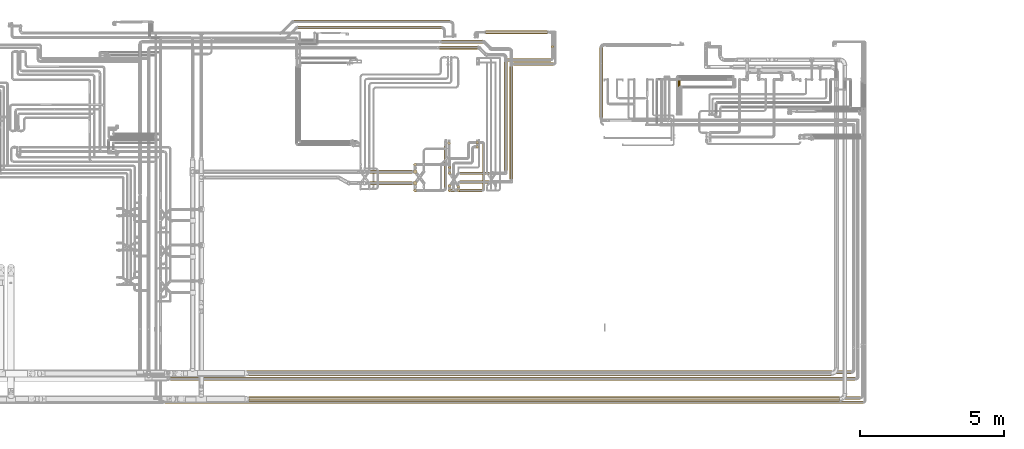
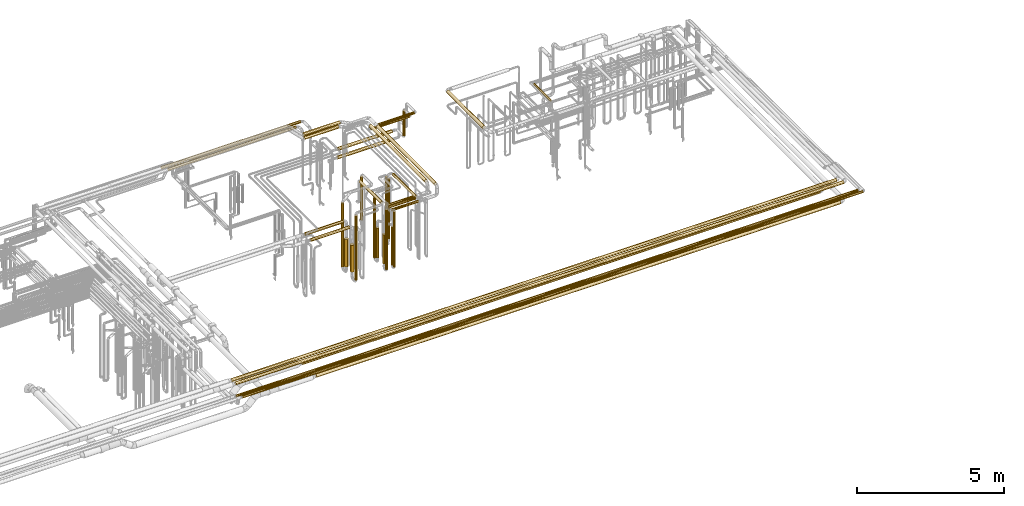
# One storey, part 7 of 827: 39 coverings.
"""IFC2X3 building model written with IfcOpenShell, lengths in millimetres."""

from ifc_helpers import new_model, entity, si_unit, converted_unit, derived_unit, direction, frame, origin, origin_2d_with_axis, place, context, subcontext, project, spatial, circle, extrude, element, save


model = new_model("IFC2X3")

# Units and contexts
model_context = context("Model", 3, precision=0.01, world=origin(), true_north=direction((6.12303176911189e-17, 1.0)))
body_context = subcontext(model_context, "Body", "Model", "MODEL_VIEW")
ifc_project = project(units=[si_unit("LENGTHUNIT", "METRE", prefix="MILLI"), si_unit("AREAUNIT", "SQUARE_METRE"), si_unit("VOLUMEUNIT", "CUBIC_METRE"), converted_unit("PLANEANGLEUNIT", "DEGREE", entity("IfcRatioMeasure", 0.0174532925199433), si_unit("PLANEANGLEUNIT", "RADIAN"), dimensions=[0, 0, 0, 0, 0, 0, 0]), si_unit("MASSUNIT", "GRAM", prefix="KILO"), derived_unit("MASSDENSITYUNIT", [(si_unit("MASSUNIT", "GRAM", prefix="KILO"), 1), (si_unit("LENGTHUNIT", "METRE"), -3)]), derived_unit("MOMENTOFINERTIAUNIT", [(si_unit("LENGTHUNIT", "METRE"), 4)]), si_unit("TIMEUNIT", "SECOND"), si_unit("FREQUENCYUNIT", "HERTZ"), si_unit("THERMODYNAMICTEMPERATUREUNIT", "DEGREE_CELSIUS"), derived_unit("THERMALTRANSMITTANCEUNIT", [(si_unit("MASSUNIT", "GRAM", prefix="KILO"), 1), (si_unit("THERMODYNAMICTEMPERATUREUNIT", "KELVIN"), -1), (si_unit("TIMEUNIT", "SECOND"), -3)]), derived_unit("VOLUMETRICFLOWRATEUNIT", [(si_unit("LENGTHUNIT", "METRE"), 3), (si_unit("TIMEUNIT", "SECOND"), -1)]), derived_unit("MASSFLOWRATEUNIT", [(si_unit("MASSUNIT", "GRAM", prefix="KILO"), 1), (si_unit("TIMEUNIT", "SECOND"), -1)]), derived_unit("ROTATIONALFREQUENCYUNIT", [(si_unit("TIMEUNIT", "SECOND"), -1)]), si_unit("ELECTRICCURRENTUNIT", "AMPERE"), si_unit("ELECTRICVOLTAGEUNIT", "VOLT"), si_unit("POWERUNIT", "WATT"), si_unit("FORCEUNIT", "NEWTON", prefix="KILO"), si_unit("ILLUMINANCEUNIT", "LUX"), si_unit("LUMINOUSFLUXUNIT", "LUMEN"), si_unit("LUMINOUSINTENSITYUNIT", "CANDELA"), derived_unit("USERDEFINED", [(si_unit("MASSUNIT", "GRAM", prefix="KILO"), -1), (si_unit("LENGTHUNIT", "METRE"), -2), (si_unit("TIMEUNIT", "SECOND"), 3), (si_unit("LUMINOUSFLUXUNIT", "LUMEN"), 1)]), derived_unit("LINEARVELOCITYUNIT", [(si_unit("LENGTHUNIT", "METRE"), 1), (si_unit("TIMEUNIT", "SECOND"), -1)]), si_unit("PRESSUREUNIT", "PASCAL"), derived_unit("USERDEFINED", [(si_unit("LENGTHUNIT", "METRE"), -2), (si_unit("MASSUNIT", "GRAM", prefix="KILO"), 1), (si_unit("TIMEUNIT", "SECOND"), -2)]), derived_unit("LINEARFORCEUNIT", [(si_unit("MASSUNIT", "GRAM", prefix="KILO"), 1), (si_unit("LENGTHUNIT", "METRE"), 1), (si_unit("TIMEUNIT", "SECOND"), -2), (si_unit("LENGTHUNIT", "METRE"), -1)]), derived_unit("PLANARFORCEUNIT", [(si_unit("MASSUNIT", "GRAM", prefix="KILO"), 1), (si_unit("LENGTHUNIT", "METRE"), 1), (si_unit("TIMEUNIT", "SECOND"), -2), (si_unit("LENGTHUNIT", "METRE"), -2)])], contexts=[model_context])

# Site, building, storey
site_placement = place(None, origin())
site = spatial("IfcSite", under=ifc_project, at=site_placement, CompositionType="ELEMENT")
building_placement = place(site_placement, origin())
building = spatial("IfcBuilding", under=site, at=building_placement, CompositionType="ELEMENT")
storey_placement = place(building_placement, frame((0.0, 0.0, 28200.0)))
storey = spatial("IfcBuildingStorey", under=building, at=storey_placement, Name="08", CompositionType="ELEMENT", Elevation=28200.0)

# Coverings
covering_1_placement = place(storey_placement, frame((48780.69, 14028.51, 2935.65)))
element("IfcCovering", 1, at=covering_1_placement, inside=storey, Name=":ADSK_", ObjectType=":ADSK_", PredefinedType="INSULATION", context=body_context, shape_type="SweptSolid", body=[
    extrude(circle(Radius=62.75, at=origin_2d_with_axis()), frame((64.35, 0.0, 64.35), z_axis=(0.0, 1.0, 0.0), x_axis=(1.0, 0.0, 0.0)), (0.0, 0.0, 1.0), 3926.02173625165),
])
covering_2_placement = place(storey_placement, frame((46413.17, 18745.48, 2935.65)))
element("IfcCovering", 2, at=covering_2_placement, inside=storey, Name=":ADSK_", ObjectType=":ADSK_", PredefinedType="INSULATION", context=body_context, shape_type="SweptSolid", body=[
    extrude(circle(Radius=62.75, at=origin_2d_with_axis()), frame((0.0, 64.35, 64.35), z_axis=(1.0, 0.0, 0.0), x_axis=(0.0, -1.0, 0.0)), (0.0, 0.0, 1.0), 1431.19890326369),
])
covering_3_placement = place(storey_placement, frame((47057.67, 13882.91, 2546.86)))
element("IfcCovering", 3, at=covering_3_placement, inside=storey, Name=":ADSK_", ObjectType=":ADSK_", PredefinedType="INSULATION", context=body_context, shape_type="SweptSolid", body=[
    extrude(circle(Radius=49.0, at=origin_2d_with_axis()), frame((0.0, 50.6, 50.6), z_axis=(1.0, 0.0, 0.0), x_axis=(0.0, -1.0, 0.0)), (0.0, 0.0, 1.0), 1048.36321743802),
])
covering_4_placement = place(storey_placement, frame((51904.03, 16167.38, 2885.66)))
element("IfcCovering", 4, at=covering_4_placement, inside=storey, Name=":ADSK_", ObjectType=":ADSK_", PredefinedType="INSULATION", context=body_context, shape_type="SweptSolid", body=[
    extrude(circle(Radius=62.75, at=origin_2d_with_axis()), frame((64.34, 0.0, 64.34), z_axis=(0.0, 1.0, 0.0), x_axis=(-0.705020157657856, 0.0, -0.709187265322843)), (0.0, 0.0, 1.0), 2437.8284365613),
])
covering_5_placement = place(storey_placement, frame((36979.83, 7015.65, 3035.65)))
element("IfcCovering", 5, at=covering_5_placement, inside=storey, Name=":ADSK_", ObjectType=":ADSK_", PredefinedType="INSULATION", context=body_context, shape_type="SweptSolid", body=[
    extrude(circle(Radius=62.75, at=origin_2d_with_axis()), frame((0.0, 64.35, 64.35), z_axis=(1.0, 0.0, 0.0), x_axis=(0.0, -1.0, 0.0)), (0.0, 0.0, 1.0), 23828.2704925099),
])
covering_6_placement = place(storey_placement, frame((48580.5, 14330.68, 2935.65)))
element("IfcCovering", 6, at=covering_6_placement, inside=storey, Name=":ADSK_", ObjectType=":ADSK_", PredefinedType="INSULATION", context=body_context, shape_type="SweptSolid", body=[
    extrude(circle(Radius=62.75, at=origin_2d_with_axis()), frame((64.35, 0.0, 64.35), z_axis=(0.0, 1.0, 0.0), x_axis=(1.0, 0.0, 0.0)), (0.0, 0.0, 1.0), 3773.85017283484),
])
covering_7_placement = place(storey_placement, frame((46333.17, 18542.35, 2935.65)))
element("IfcCovering", 7, at=covering_7_placement, inside=storey, Name=":ADSK_", ObjectType=":ADSK_", PredefinedType="INSULATION", context=body_context, shape_type="SweptSolid", body=[
    extrude(circle(Radius=62.75, at=origin_2d_with_axis()), frame((0.0, 64.35, 64.35), z_axis=(1.0, 0.0, 0.0), x_axis=(0.0, -1.0, 0.0)), (0.0, 0.0, 1.0), 1341.29942314912),
])
covering_8_placement = place(storey_placement, frame((47053.03, 14185.08, 2554.4)))
element("IfcCovering", 8, at=covering_8_placement, inside=storey, Name=":ADSK_", ObjectType=":ADSK_", PredefinedType="INSULATION", context=body_context, shape_type="SweptSolid", body=[
    extrude(circle(Radius=49.0, at=origin_2d_with_axis()), frame((0.0, 50.6, 50.6), z_axis=(1.0, 0.0, 0.0), x_axis=(0.0, -1.0, 0.0)), (0.0, 0.0, 1.0), 1022.80865450649),
])
covering_9_placement = place(storey_placement, frame((39691.04, 7183.11, 2816.78)))
element("IfcCovering", 9, at=covering_9_placement, inside=storey, Name=":ADSK_", ObjectType=":ADSK_", PredefinedType="INSULATION", context=body_context, shape_type="SweptSolid", body=[
    extrude(circle(Radius=81.5, at=origin_2d_with_axis()), frame((0.0, 83.1, 83.1), z_axis=(1.0, 0.0, 4.27481930448548e-06), x_axis=(0.0, -1.0, 0.0)), (0.0, 0.0, 1.0), 20277.5004791467),
])
covering_10_placement = place(storey_placement, frame((43864.22, 14225.77, 2439.15)))
element("IfcCovering", 10, at=covering_10_placement, inside=storey, Name=":ADSK_", ObjectType=":ADSK_", PredefinedType="INSULATION", context=body_context, shape_type="SweptSolid", body=[
    extrude(circle(Radius=59.25, at=origin_2d_with_axis()), frame((0.0, 60.85, 60.85), z_axis=(1.0, 0.0, 0.0), x_axis=(0.0, -1.0, 0.0)), (0.0, 0.0, 1.0), 1516.0),
])
covering_11_placement = place(storey_placement, frame((41411.59, 19252.89, 2945.65)))
element("IfcCovering", 11, at=covering_11_placement, inside=storey, Name=":ADSK_", ObjectType=":ADSK_", PredefinedType="INSULATION", context=body_context, shape_type="SweptSolid", body=[
    extrude(circle(Radius=52.75, at=origin_2d_with_axis()), frame((0.0, 54.35, 54.35), z_axis=(1.0, 0.0, 0.0), x_axis=(0.0, 1.0, 0.0)), (0.0, 0.0, 1.0), 5001.22814555646),
])
covering_12_placement = place(storey_placement, frame((36633.72, 6365.97, 3049.4)))
element("IfcCovering", 12, at=covering_12_placement, inside=storey, Name=":ADSK_", ObjectType=":ADSK_", PredefinedType="INSULATION", context=body_context, shape_type="SweptSolid", body=[
    extrude(circle(Radius=49.0, at=origin_2d_with_axis()), frame((0.0, 50.6, 50.6), z_axis=(1.0, 0.0, 0.0), x_axis=(0.0, -1.0, 0.0)), (0.0, 0.0, 1.0), 24361.9213538406),
])
covering_13_placement = place(storey_placement, frame((36794.64, 6215.11, 3049.4)))
element("IfcCovering", 13, at=covering_13_placement, inside=storey, Name=":ADSK_", ObjectType=":ADSK_", PredefinedType="INSULATION", context=body_context, shape_type="SweptSolid", body=[
    extrude(circle(Radius=49.0, at=origin_2d_with_axis()), frame((0.0, 50.6, 50.6), z_axis=(1.0, 0.0, 0.0), x_axis=(0.0, -1.0, 0.0)), (0.0, 0.0, 1.0), 24300.9943574319),
])
covering_14_placement = place(storey_placement, frame((54648.84, 16326.56, 2956.65)))
element("IfcCovering", 14, at=covering_14_placement, inside=storey, Name=":ADSK_", ObjectType=":ADSK_", PredefinedType="INSULATION", context=body_context, shape_type="SweptSolid", body=[
    extrude(circle(Radius=41.75, at=origin_2d_with_axis()), frame((43.35, 0.0, 43.35), z_axis=(0.0, 1.0, 0.0), x_axis=(1.0, 0.0, 0.0)), (0.0, 0.0, 1.0), 1135.43813554226),
])
covering_15_placement = place(storey_placement, frame((46642.19, 14383.93, 457.0)))
element("IfcCovering", 15, at=covering_15_placement, inside=storey, Name=":ADSK_", ObjectType=":ADSK_", PredefinedType="INSULATION", context=body_context, shape_type="SweptSolid", body=[
    extrude(circle(Radius=49.0, at=origin_2d_with_axis()), frame((50.6, 50.6, 0.0)), (0.0, 0.0, 1.0), 2486.00000000001),
])
covering_16_placement = place(storey_placement, frame((47601.15, 15256.43, 1498.5)))
element("IfcCovering", 16, at=covering_16_placement, inside=storey, Name=":ADSK_", ObjectType=":ADSK_", PredefinedType="INSULATION", context=body_context, shape_type="SweptSolid", body=[
    extrude(circle(Radius=49.0, at=origin_2d_with_axis()), frame((50.6, 50.6, 0.0), z_axis=(0.0, 0.0, 1.0), x_axis=(0.0, 1.0, 0.0)), (0.0, 0.0, 1.0), 1444.50064453807),
])
covering_17_placement = place(storey_placement, frame((46636.19, 14182.93, 586.0)))
element("IfcCovering", 17, at=covering_17_placement, inside=storey, Name=":ADSK_", ObjectType=":ADSK_", PredefinedType="INSULATION", context=body_context, shape_type="SweptSolid", body=[
    extrude(circle(Radius=55.0, at=origin_2d_with_axis()), frame((56.6, 56.6, 0.0), z_axis=(0.0, 0.0, 1.0), x_axis=(0.0, -1.0, 0.0)), (0.0, 0.0, 1.0), 1235.49999999998),
])
covering_18_placement = place(storey_placement, frame((47833.42, 13693.84, 2949.4)))
element("IfcCovering", 18, at=covering_18_placement, inside=storey, Name=":ADSK_", ObjectType=":ADSK_", PredefinedType="INSULATION", context=body_context, shape_type="SweptSolid", body=[
    extrude(circle(Radius=49.0, at=origin_2d_with_axis()), frame((50.6, 0.0, 50.6), z_axis=(0.0, 1.0, 0.0), x_axis=(-1.0, 0.0, 0.0)), (0.0, 0.0, 1.0), 1556.18693752511),
])
covering_19_placement = place(storey_placement, frame((46642.19, 13586.24, 457.0)))
element("IfcCovering", 19, at=covering_19_placement, inside=storey, Name=":ADSK_", ObjectType=":ADSK_", PredefinedType="INSULATION", context=body_context, shape_type="SweptSolid", body=[
    extrude(circle(Radius=49.0, at=origin_2d_with_axis()), frame((50.6, 50.6, 0.0), z_axis=(0.0, 0.0, 1.0), x_axis=(0.0, 1.0, 0.0)), (0.0, 0.0, 1.0), 2486.00000000002),
])
covering_20_placement = place(storey_placement, frame((46749.79, 13586.24, 2949.4)))
element("IfcCovering", 20, at=covering_20_placement, inside=storey, Name=":ADSK_", ObjectType=":ADSK_", PredefinedType="INSULATION", context=body_context, shape_type="SweptSolid", body=[
    extrude(circle(Radius=49.0, at=origin_2d_with_axis()), frame((0.0, 50.6, 50.6), z_axis=(1.0, 0.0, 0.0), x_axis=(0.0, -1.0, 0.0)), (0.0, 0.0, 1.0), 1077.22604286538),
])
covering_21_placement = place(storey_placement, frame((46636.19, 13731.91, 617.02)))
element("IfcCovering", 21, at=covering_21_placement, inside=storey, Name=":ADSK_", ObjectType=":ADSK_", PredefinedType="INSULATION", context=body_context, shape_type="SweptSolid", body=[
    extrude(circle(Radius=55.0, at=origin_2d_with_axis()), frame((56.6, 56.6, 0.0), z_axis=(0.0, 0.0, 1.0), x_axis=(0.0, -1.0, 0.0)), (0.0, 0.0, 1.0), 1204.4784639113),
])
covering_22_placement = place(storey_placement, frame((46947.93, 13586.25, 456.98)))
element("IfcCovering", 22, at=covering_22_placement, inside=storey, Name=":ADSK_", ObjectType=":ADSK_", PredefinedType="INSULATION", context=body_context, shape_type="SweptSolid", body=[
    extrude(circle(Radius=49.0, at=origin_2d_with_axis()), frame((50.6, 50.97, 0.01), z_axis=(-2.64985640330363e-08, -0.000162783161270818, 0.999999986750821), x_axis=(1.0, -7.51245479154553e-08, 2.64863353725597e-08)), (0.0, 0.0, 1.0), 2295.79650227157),
])
covering_23_placement = place(storey_placement, frame((47601.15, 15100.64, 477.25)))
element("IfcCovering", 23, at=covering_23_placement, inside=storey, Name=":ADSK_", ObjectType=":ADSK_", PredefinedType="INSULATION", context=body_context, shape_type="SweptSolid", body=[
    extrude(circle(Radius=49.0, at=origin_2d_with_axis()), frame((50.6, 50.6, 0.0), z_axis=(0.0, 0.0, 1.0), x_axis=(-1.0, 0.0, 0.0)), (0.0, 0.0, 1.0), 2465.75),
])
covering_24_placement = place(storey_placement, frame((46948.0, 13713.24, 457.0)))
element("IfcCovering", 24, at=covering_24_placement, inside=storey, Name=":ADSK_", ObjectType=":ADSK_", PredefinedType="INSULATION", context=body_context, shape_type="SweptSolid", body=[
    extrude(circle(Radius=49.0, at=origin_2d_with_axis()), frame((50.53, 50.53, 0.0), z_axis=(0.0, 0.0, 1.0), x_axis=(0.839206573460922, 0.543812768386306, 0.0)), (0.0, 0.0, 1.0), 1586.11232988612),
])
covering_25_placement = place(storey_placement, frame((48701.84, 18129.93, 2749.4)))
element("IfcCovering", 25, at=covering_25_placement, inside=storey, Name=":ADSK_", ObjectType=":ADSK_", PredefinedType="INSULATION", context=body_context, shape_type="SweptSolid", body=[
    extrude(circle(Radius=49.0, at=origin_2d_with_axis()), frame((0.0, 50.6, 50.6), z_axis=(1.0, 0.0, 0.0), x_axis=(0.0, 1.0, 0.0)), (0.0, 0.0, 1.0), 1513.19134551545),
])
covering_26_placement = place(storey_placement, frame((50221.44, 18589.93, 1707.0)))
element("IfcCovering", 26, at=covering_26_placement, inside=storey, Name=":ADSK_", ObjectType=":ADSK_", PredefinedType="INSULATION", context=body_context, shape_type="SweptSolid", body=[
    extrude(circle(Radius=49.0, at=origin_2d_with_axis()), frame((50.6, 50.6, 0.0), z_axis=(0.0, 0.0, 1.0), x_axis=(-1.0, 0.0, 0.0)), (0.0, 0.0, 1.0), 1036.00000000006),
])
covering_27_placement = place(storey_placement, frame((47963.3, 19076.88, 1585.65)))
element("IfcCovering", 27, at=covering_27_placement, inside=storey, Name=":ADSK_", ObjectType=":ADSK_", PredefinedType="INSULATION", context=body_context, shape_type="SweptSolid", body=[
    extrude(circle(Radius=62.75, at=origin_2d_with_axis()), frame((0.0, 64.35, 64.35), z_axis=(1.0, 0.0, 0.0), x_axis=(0.0, 1.0, 0.0)), (0.0, 0.0, 1.0), 2120.0),
])
covering_28_placement = place(storey_placement, frame((48912.03, 17979.93, 2949.4)))
element("IfcCovering", 28, at=covering_28_placement, inside=storey, Name=":ADSK_", ObjectType=":ADSK_", PredefinedType="INSULATION", context=body_context, shape_type="SweptSolid", body=[
    extrude(circle(Radius=49.0, at=origin_2d_with_axis()), frame((0.0, 50.6, 50.6), z_axis=(1.0, 0.0, 0.0), x_axis=(0.0, 1.0, 0.0)), (0.0, 0.0, 1.0), 1403.0),
])
covering_29_placement = place(storey_placement, frame((47950.3, 19076.88, 1235.65)))
element("IfcCovering", 29, at=covering_29_placement, inside=storey, Name=":ADSK_", ObjectType=":ADSK_", PredefinedType="INSULATION", context=body_context, shape_type="SweptSolid", body=[
    extrude(circle(Radius=62.75, at=origin_2d_with_axis()), frame((0.0, 64.35, 64.35), z_axis=(1.0, 0.0, 0.0), x_axis=(0.0, -1.0, 0.0)), (0.0, 0.0, 1.0), 2145.73797712595),
])
covering_30_placement = place(storey_placement, frame((45439.88, 14483.73, 445.0)))
element("IfcCovering", 30, at=covering_30_placement, inside=storey, Name=":ADSK_", ObjectType=":ADSK_", PredefinedType="INSULATION", context=body_context, shape_type="SweptSolid", body=[
    extrude(circle(Radius=52.75, at=origin_2d_with_axis()), frame((54.35, 54.35, 0.0), z_axis=(0.0, 0.0, 1.0), x_axis=(-1.0, 0.0, 0.0)), (0.0, 0.0, 1.0), 2637.31109246141),
])
covering_31_placement = place(storey_placement, frame((46616.22, 15223.73, 1518.25)))
element("IfcCovering", 31, at=covering_31_placement, inside=storey, Name=":ADSK_", ObjectType=":ADSK_", PredefinedType="INSULATION", context=body_context, shape_type="SweptSolid", body=[
    extrude(circle(Radius=52.75, at=origin_2d_with_axis()), frame((54.35, 54.35, 0.0)), (0.0, 0.0, 1.0), 1786.75000000002),
])
covering_32_placement = place(storey_placement, frame((45420.63, 14213.02, 612.0)))
element("IfcCovering", 32, at=covering_32_placement, inside=storey, Name=":ADSK_", ObjectType=":ADSK_", PredefinedType="INSULATION", context=body_context, shape_type="SweptSolid", body=[
    extrude(circle(Radius=72.0, at=origin_2d_with_axis()), frame((73.6, 73.6, 0.0), z_axis=(0.0, 0.0, 1.0), x_axis=(0.0, -1.0, 0.0)), (0.0, 0.0, 1.0), 1140.0),
])
covering_33_placement = place(storey_placement, frame((39715.11, 6291.9, 2816.9)))
element("IfcCovering", 33, at=covering_33_placement, inside=storey, Name=":ADSK_", ObjectType=":ADSK_", PredefinedType="INSULATION", context=body_context, shape_type="SweptSolid", body=[
    extrude(circle(Radius=81.5, at=origin_2d_with_axis()), frame((0.0, 83.1, 83.1), z_axis=(1.0, 0.0, 0.0), x_axis=(0.0, -1.0, 0.0)), (0.0, 0.0, 1.0), 20545.9401755387),
])
covering_34_placement = place(storey_placement, frame((45438.93, 13582.49, 445.0)))
element("IfcCovering", 34, at=covering_34_placement, inside=storey, Name=":ADSK_", ObjectType=":ADSK_", PredefinedType="INSULATION", context=body_context, shape_type="SweptSolid", body=[
    extrude(circle(Radius=52.75, at=origin_2d_with_axis()), frame((54.35, 54.35, 0.0), z_axis=(0.0, 0.0, 1.0), x_axis=(-1.0, 0.0, 0.0)), (0.0, 0.0, 1.0), 2660.05000000001),
])
covering_35_placement = place(storey_placement, frame((46502.43, 13731.84, 3145.7)))
element("IfcCovering", 35, at=covering_35_placement, inside=storey, Name=":ADSK_", ObjectType=":ADSK_", PredefinedType="INSULATION", context=body_context, shape_type="SweptSolid", body=[
    extrude(circle(Radius=52.75, at=origin_2d_with_axis()), frame((54.35, 0.0, 54.35), z_axis=(0.0, 1.0, 0.0), x_axis=(1.0, 0.0, 0.0)), (0.0, 0.0, 1.0), 1448.52294976441),
])
covering_36_placement = place(storey_placement, frame((43856.18, 13829.33, 2439.15)))
element("IfcCovering", 36, at=covering_36_placement, inside=storey, Name=":ADSK_", ObjectType=":ADSK_", PredefinedType="INSULATION", context=body_context, shape_type="SweptSolid", body=[
    extrude(circle(Radius=59.25, at=origin_2d_with_axis()), frame((0.0, 60.85, 60.85), z_axis=(1.0, 0.0, 0.0), x_axis=(0.0, -1.0, 0.0)), (0.0, 0.0, 1.0), 1523.09721919177),
])
covering_37_placement = place(storey_placement, frame((41264.57, 19452.64, 2945.4)))
element("IfcCovering", 37, at=covering_37_placement, inside=storey, Name=":ADSK_", ObjectType=":ADSK_", PredefinedType="INSULATION", context=body_context, shape_type="SweptSolid", body=[
    extrude(circle(Radius=53.0, at=origin_2d_with_axis()), frame((0.0, 54.6, 54.6), z_axis=(1.0, 0.0, 0.0), x_axis=(0.0, -1.0, 0.0)), (0.0, 0.0, 1.0), 5448.24882079875),
])
covering_38_placement = place(storey_placement, frame((45419.68, 13816.58, 643.02)))
element("IfcCovering", 38, at=covering_38_placement, inside=storey, Name=":ADSK_", ObjectType=":ADSK_", PredefinedType="INSULATION", context=body_context, shape_type="SweptSolid", body=[
    extrude(circle(Radius=72.0, at=origin_2d_with_axis()), frame((73.6, 73.6, 0.0), z_axis=(0.0, 0.0, 1.0), x_axis=(0.0, -1.0, 0.0)), (0.0, 0.0, 1.0), 1114.97846391128),
])
covering_39_placement = place(storey_placement, frame((36962.03, 7245.65, 3035.65)))
element("IfcCovering", 39, at=covering_39_placement, inside=storey, Name=":ADSK_", ObjectType=":ADSK_", PredefinedType="INSULATION", context=body_context, shape_type="SweptSolid", body=[
    extrude(circle(Radius=62.75, at=origin_2d_with_axis()), frame((0.0, 64.35, 64.35), z_axis=(1.0, 0.0, 0.0), x_axis=(0.0, 1.0, 0.0)), (0.0, 0.0, 1.0), 23696.06979),
])

save(model, "model.ifc")
